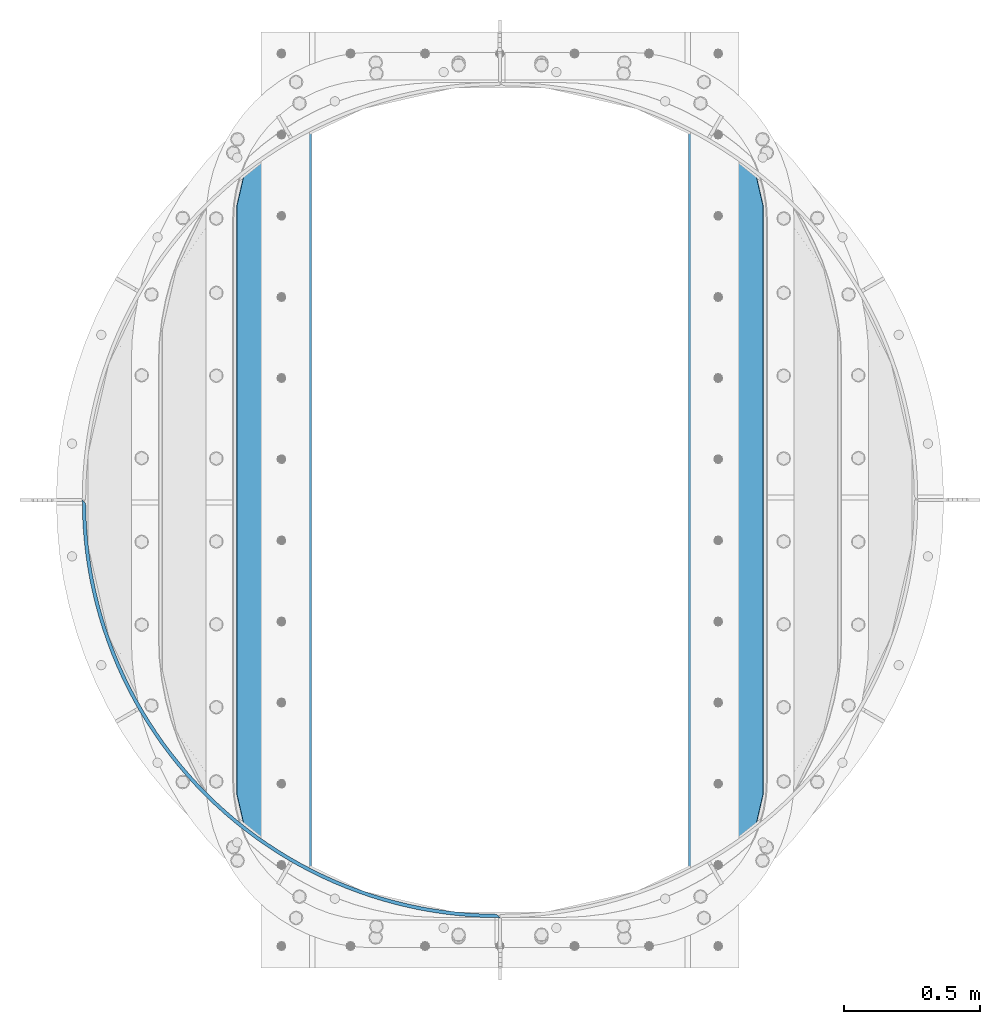
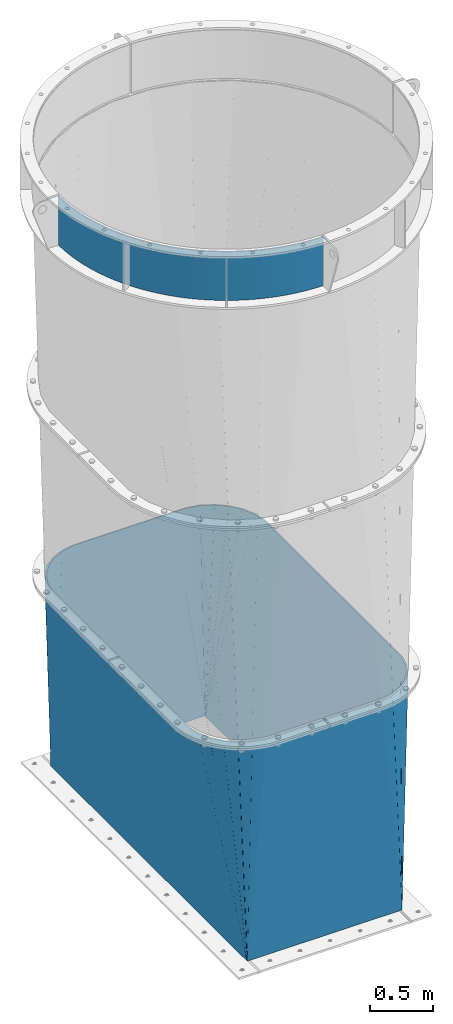
# One storey, part 6 of 15: 2 beams, 2 elements without a shape of their own.
"""IFC2X3 building model written with IfcOpenShell, lengths in millimetres."""

from ifc_helpers import new_model, si_unit, frame, origin_with_axes, place, context, subcontext, project, spatial, faceted_brep, material, type_object, element, aggregate, save


model = new_model("IFC2X3")

# Units and contexts
model_context = context("Model", 3, precision=1e-05, world=origin_with_axes())
body_context = subcontext(model_context, "Body", "Model", "MODEL_VIEW")
ifc_project = project(units=[si_unit("LENGTHUNIT", "METRE", prefix="MILLI"), si_unit("AREAUNIT", "SQUARE_METRE"), si_unit("VOLUMEUNIT", "CUBIC_METRE"), si_unit("MASSUNIT", "GRAM", prefix="KILO"), si_unit("TIMEUNIT", "SECOND"), si_unit("PLANEANGLEUNIT", "RADIAN"), si_unit("SOLIDANGLEUNIT", "STERADIAN"), si_unit("THERMODYNAMICTEMPERATUREUNIT", "DEGREE_CELSIUS"), si_unit("LUMINOUSINTENSITYUNIT", "LUMEN")], contexts=[model_context])

# Site, building, storey
site_placement = place(None, origin_with_axes())
site = spatial("IfcSite", under=ifc_project, at=site_placement, CompositionType="ELEMENT")
building_placement = place(site_placement, origin_with_axes())
building = spatial("IfcBuilding", under=site, at=building_placement, Name="Undefined", CompositionType="ELEMENT")
storey_placement = place(building_placement, origin_with_axes())
storey = spatial("IfcBuildingStorey", under=building, at=storey_placement, Name="Undefined", CompositionType="ELEMENT", Elevation=0.0)

# Assembly, beam
assembly_1_placement = place(storey_placement, origin_with_axes())
assembly_1 = element("IfcElementAssembly", 1, at=assembly_1_placement, inside=storey, Name="TRANSITION", AssemblyPlace="NOTDEFINED", PredefinedType="RIGID_FRAME")
ifc_material = material(Name="STEEL/A36")
beam_type_1 = type_object("IfcBeamType", PredefinedType="NOTDEFINED")
beam_1_placement = place(assembly_1_placement, frame((879.47499999978, 190.499999999732, 6518.28), z_axis=(0.0, 0.0, 1.0), x_axis=(-0.707106781186548, 0.707106781186548, 0.0)))
beam_1 = element("IfcBeam", 2, at=beam_1_placement, type_object=beam_type_1, material=ifc_material, Name="PLATE", context=body_context, shape_type="Brep", body=[
    faceted_brep([(2168.73185323846, 4.4901280603583, 234.95), (2150.63139313598, 4.34796445618963, 234.95), (2150.63139313598, 4.34796445618963, -234.95), (2168.73185323846, 4.4901280603583, -234.95), (13.6103320421265, 4.34796445619054, 234.95), (-4.49012806053565, 4.49012806053361, 234.95), (-4.49012806053565, 4.49012806053361, -234.95), (13.6103320421265, 4.34796445619054, -234.95), (30.1773249082131, 38.0852271696592, 234.95), (30.1773249082131, 38.0852271696592, -234.95), (38.8710731535093, 28.8273256014088, -234.95), (38.8710731535093, 28.8273256014088, 234.95), (65.8829191459708, 70.5748181123124, 234.95), (65.8829191459708, 70.5748181123124, -234.95), (74.2815798355832, 61.0484075280069, -234.95), (74.2815798355832, 61.0484075280069, 234.95), (102.591417542014, 101.92683758475, 234.95), (102.591417542014, 101.92683758475, -234.95), (110.686702211824, 92.1413194014985, -234.95), (110.686702211824, 92.1413194014985, 234.95), (140.266593240295, 132.110344928926, 234.95), (140.266593240295, 132.110344928926, -234.95), (148.05051282169, 122.075376271756, -234.95), (148.05051282169, 122.075376271756, 234.95), (178.871265390981, 161.095552667193, 234.95), (178.871265390981, 161.095552667193, -234.95), (186.336138095097, 150.821036838632, -234.95), (186.336138095097, 150.821036838632, 234.95), (218.367335843456, 188.853855898938, 234.95), (218.367335843456, 188.853855898938, -234.95), (225.50579474218, 178.349932605652, -234.95), (225.50579474218, 178.349932605652, 234.95), (258.715826744602, 215.357860530173, 234.95), (258.715826744602, 215.357860530173, -234.95), (265.520827040837, 204.634895876298, -234.95), (265.520827040837, 204.634895876298, 234.95), (299.876919005232, 240.581410308193, 234.95), (299.876919005232, 240.581410308193, -234.95), (306.341744985264, 229.649986565244, -234.95), (306.341744985264, 229.649986565244, 234.95), (341.809991596724, 264.499612634644, 234.95), (341.809991596724, 264.499612634644, -234.95), (347.928263257818, 253.370517798088, -234.95), (347.928263257818, 253.370517798088, 234.95), (384.473661639071, 287.088863131509, 234.95), (384.473661639071, 287.088863131509, -234.95), (390.239340985765, 275.773080274318, -234.95), (390.239340985765, 275.773080274318, 234.95), (427.825825240789, 308.326868935782, 234.95), (427.825825240789, 308.326868935782, -234.95), (433.233222243668, 296.835565369465, -234.95), (433.233222243668, 296.835565369465, 234.95), (471.823699050373, 328.192670699828, 234.95), (471.823699050373, 328.192670699828, -234.95), (476.867477261437, 316.537186953643, -234.95), (476.867477261437, 316.537186953643, 234.95), (516.423862478301, 346.666663275734, 234.95), (516.423862478301, 346.666663275734, -234.95), (521.099044297397, 334.858501904954, -234.95), (521.099044297397, 334.858501904954, 234.95), (561.582300547911, 363.73061506322, 234.95), (561.582300547911, 363.73061506322, -234.95), (565.884272135028, 351.781429297502, -234.95), (565.884272135028, 351.781429297502, 234.95), (607.254447332874, 379.367686002027, 234.95), (607.254447332874, 379.367686002027, -234.95), (611.178963161437, 367.289268245079, -234.95), (611.178963161437, 367.289268245079, 234.95), (653.395229938378, 393.562444191024, 234.95), (653.395229938378, 393.562444191024, -234.95), (656.938416985078, 381.366714382928, -234.95), (656.938416985078, 381.366714382928, 234.95), (699.959112982635, 406.300881117635, 234.95), (699.959112982635, 406.300881117635, -234.95), (703.11747454963, 393.999874971302, -234.95), (703.11747454963, 393.999874971302, 234.95), (746.900143534807, 417.570425482542, 234.95), (746.900143534807, 417.570425482542, -234.95), (749.670562700545, 405.17628260592, -234.95), (749.670562700545, 405.17628260592, 234.95), (794.171996464998, 427.359955606045, 234.95), (794.171996464998, 427.359955606045, -234.95), (796.551739160238, 414.884907521791, -234.95), (796.551739160238, 414.884907521791, 234.95), (841.728020161566, 435.659810403817, 234.95), (841.728020161566, 435.659810403817, -234.95), (843.714737867578, 423.116168478259, -234.95), (843.714737867578, 423.116168478259, 234.95), (889.52128257063, 442.461798921226, 234.95), (889.52128257063, 442.461798921226, -234.95), (891.113014636898, 429.861942214533, -234.95), (891.113014636898, 429.861942214533, 234.95), (937.504617512343, 447.759208416819, 234.95), (937.504617512343, 447.759208416819, -234.95), (938.699793091489, 435.115571466361, -234.95), (938.699793091489, 435.115571466361, 234.95), (985.630671228216, 451.546810986989, 234.95), (985.630671228216, 451.546810986989, -234.95), (986.42811082624, 438.871871535951, -234.95), (986.42811082624, 438.871871535951, 234.95), (1033.85194911356, 453.820868725281, 234.95), (1033.85194911356, 453.820868725281, -234.95), (1034.25086575385, 441.127135408636, -234.95), (1034.25086575385, 441.127135408636, 234.95), (1082.12086258893, 454.579137411258, 234.95), (1082.12086258893, 454.579137411258, -234.95), (1082.12086258893, 441.879137411258, -234.95), (1082.12086258893, 441.879137411258, 234.95), (1130.3897760643, 453.820868725272, 234.95), (1130.3897760643, 453.820868725272, -234.95), (1129.99085942401, 441.127135408629, -234.95), (1129.99085942401, 441.127135408629, 234.95), (1178.61105394964, 451.546810986973, 234.95), (1178.61105394964, 451.546810986973, -234.95), (1177.81361435162, 438.871871535935, -234.95), (1177.81361435162, 438.871871535935, 234.95), (1226.73710766552, 447.759208416796, 234.95), (1226.73710766552, 447.759208416796, -234.95), (1225.54193208637, 435.115571466338, -234.95), (1225.54193208637, 435.115571466338, 234.95), (1274.72044260723, 442.461798921194, 234.95), (1274.72044260723, 442.461798921194, -234.95), (1273.12871054096, 429.861942214502, -234.95), (1273.12871054096, 429.861942214502, 234.95), (1322.51370501629, 435.659810403778, 234.95), (1322.51370501629, 435.659810403778, -234.95), (1320.52698731028, 423.116168478221, -234.95), (1320.52698731028, 423.116168478221, 234.95), (1370.06972871286, 427.359955605998, 234.95), (1370.06972871286, 427.359955605998, -234.95), (1367.68998601762, 414.884907521745, -234.95), (1367.68998601762, 414.884907521745, 234.95), (1417.34158164306, 417.570425482488, 234.95), (1417.34158164306, 417.570425482488, -234.95), (1414.57116247732, 405.176282605867, -234.95), (1414.57116247732, 405.176282605867, 234.95), (1464.28261219523, 406.300881117574, 234.95), (1464.28261219523, 406.300881117574, -234.95), (1461.12425062824, 393.999874971241, -234.95), (1461.12425062824, 393.999874971241, 234.95), (1510.84649523949, 393.562444190955, 234.95), (1510.84649523949, 393.562444190955, -234.95), (1507.30330819279, 381.36671438286, -234.95), (1507.30330819279, 381.36671438286, 234.95), (1556.98727784499, 379.36768600195, 234.95), (1556.98727784499, 379.36768600195, -234.95), (1553.06276201643, 367.289268245003, -234.95), (1553.06276201643, 367.289268245003, 234.95), (1602.65942462996, 363.730615063135, 234.95), (1602.65942462996, 363.730615063135, -234.95), (1598.35745304285, 351.781429297419, -234.95), (1598.35745304285, 351.781429297419, 234.95), (1647.81786269957, 346.666663275642, 234.95), (1647.81786269957, 346.666663275642, -234.95), (1643.14268088048, 334.858501904863, -234.95), (1643.14268088048, 334.858501904863, 234.95), (1692.4180261275, 328.192670699729, 234.95), (1692.4180261275, 328.192670699729, -234.95), (1687.37424791644, 316.537186953544, -234.95), (1687.37424791644, 316.537186953544, 234.95), (1736.41589993709, 308.326868935676, 234.95), (1736.41589993709, 308.326868935676, -234.95), (1731.00850293421, 296.835565369359, -234.95), (1731.00850293421, 296.835565369359, 234.95), (1779.76806353881, 287.088863131397, 234.95), (1779.76806353881, 287.088863131397, -234.95), (1774.00238419212, 275.773080274206, -234.95), (1774.00238419212, 275.773080274206, 234.95), (1822.43173358116, 264.499612634525, 234.95), (1822.43173358116, 264.499612634525, -234.95), (1816.31346192007, 253.370517797969, -234.95), (1816.31346192007, 253.370517797969, 234.95), (1864.36480617266, 240.581410308067, 234.95), (1864.36480617266, 240.581410308067, -234.95), (1857.89998019263, 229.649986565118, -234.95), (1857.89998019263, 229.649986565118, 234.95), (1905.52589843329, 215.357860530039, 234.95), (1905.52589843329, 215.357860530039, -234.95), (1898.72089813706, 204.634895876166, -234.95), (1898.72089813706, 204.634895876166, 234.95), (1945.87438933444, 188.853855898798, 234.95), (1945.87438933444, 188.853855898798, -234.95), (1938.73593043572, 178.349932605514, -234.95), (1938.73593043572, 178.349932605514, 234.95), (1985.37045978692, 161.095552667047, 234.95), (1985.37045978692, 161.095552667047, -234.95), (1977.90558708281, 150.821036838488, -234.95), (1977.90558708281, 150.821036838488, 234.95), (2023.97513193761, 132.110344928774, 234.95), (2023.97513193761, 132.110344928774, -234.95), (2016.19121235622, 122.075376271606, -234.95), (2016.19121235622, 122.075376271606, 234.95), (2061.6503076359, 101.926837584591, 234.95), (2061.6503076359, 101.926837584591, -234.95), (2053.55502296609, 92.1413194013419, -234.95), (2053.55502296609, 92.1413194013419, 234.95), (2098.35880603195, 70.5748181121483, 234.95), (2098.35880603195, 70.5748181121483, -234.95), (2089.96014534234, 61.0484075278443, -234.95), (2089.96014534234, 61.0484075278443, 234.95), (2134.06440026971, 38.0852271694891, 234.95), (2134.06440026971, 38.0852271694891, -234.95), (2125.37065202442, 28.8273256012403, -234.95), (2125.37065202442, 28.8273256012403, 234.95)], [[[0, 1, 2, 3]], [[4, 5, 6, 7]], [[6, 5, 8, 9]], [[10, 11, 4, 7]], [[9, 8, 12, 13]], [[11, 10, 14, 15]], [[13, 12, 16, 17]], [[15, 14, 18, 19]], [[17, 16, 20, 21]], [[19, 18, 22, 23]], [[21, 20, 24, 25]], [[23, 22, 26, 27]], [[25, 24, 28, 29]], [[27, 26, 30, 31]], [[29, 28, 32, 33]], [[31, 30, 34, 35]], [[33, 32, 36, 37]], [[35, 34, 38, 39]], [[37, 36, 40, 41]], [[39, 38, 42, 43]], [[41, 40, 44, 45]], [[43, 42, 46, 47]], [[45, 44, 48, 49]], [[47, 46, 50, 51]], [[49, 48, 52, 53]], [[51, 50, 54, 55]], [[53, 52, 56, 57]], [[55, 54, 58, 59]], [[57, 56, 60, 61]], [[59, 58, 62, 63]], [[61, 60, 64, 65]], [[63, 62, 66, 67]], [[65, 64, 68, 69]], [[67, 66, 70, 71]], [[69, 68, 72, 73]], [[71, 70, 74, 75]], [[73, 72, 76, 77]], [[75, 74, 78, 79]], [[77, 76, 80, 81]], [[79, 78, 82, 83]], [[81, 80, 84, 85]], [[83, 82, 86, 87]], [[85, 84, 88, 89]], [[87, 86, 90, 91]], [[89, 88, 92, 93]], [[91, 90, 94, 95]], [[93, 92, 96, 97]], [[95, 94, 98, 99]], [[97, 96, 100, 101]], [[99, 98, 102, 103]], [[101, 100, 104, 105]], [[103, 102, 106, 107]], [[105, 104, 108, 109]], [[107, 106, 110, 111]], [[109, 108, 112, 113]], [[111, 110, 114, 115]], [[113, 112, 116, 117]], [[115, 114, 118, 119]], [[117, 116, 120, 121]], [[119, 118, 122, 123]], [[121, 120, 124, 125]], [[123, 122, 126, 127]], [[125, 124, 128, 129]], [[127, 126, 130, 131]], [[129, 128, 132, 133]], [[131, 130, 134, 135]], [[133, 132, 136, 137]], [[135, 134, 138, 139]], [[137, 136, 140, 141]], [[139, 138, 142, 143]], [[141, 140, 144, 145]], [[143, 142, 146, 147]], [[145, 144, 148, 149]], [[147, 146, 150, 151]], [[149, 148, 152, 153]], [[151, 150, 154, 155]], [[153, 152, 156, 157]], [[155, 154, 158, 159]], [[157, 156, 160, 161]], [[159, 158, 162, 163]], [[161, 160, 164, 165]], [[163, 162, 166, 167]], [[165, 164, 168, 169]], [[167, 166, 170, 171]], [[169, 168, 172, 173]], [[171, 170, 174, 175]], [[173, 172, 176, 177]], [[175, 174, 178, 179]], [[177, 176, 180, 181]], [[179, 178, 182, 183]], [[181, 180, 184, 185]], [[183, 182, 186, 187]], [[185, 184, 188, 189]], [[187, 186, 190, 191]], [[189, 188, 192, 193]], [[191, 190, 194, 195]], [[193, 192, 196, 197]], [[195, 194, 198, 199]], [[197, 196, 200, 201]], [[199, 198, 202, 203]], [[201, 200, 0, 3]], [[200, 196, 192, 188, 184, 180, 176, 172, 168, 164, 160, 156, 152, 148, 144, 140, 136, 132, 128, 124, 120, 116, 112, 108, 104, 100, 96, 92, 88, 84, 80, 76, 72, 68, 64, 60, 56, 52, 48, 44, 40, 36, 32, 28, 24, 20, 16, 12, 8, 5, 4, 11, 15, 19, 23, 27, 31, 35, 39, 43, 47, 51, 55, 59, 63, 67, 71, 75, 79, 83, 87, 91, 95, 99, 103, 107, 111, 115, 119, 123, 127, 131, 135, 139, 143, 147, 151, 155, 159, 163, 167, 171, 175, 179, 183, 187, 191, 195, 199, 203, 1, 0]], [[203, 202, 2, 1]], [[202, 198, 194, 190, 186, 182, 178, 174, 170, 166, 162, 158, 154, 150, 146, 142, 138, 134, 130, 126, 122, 118, 114, 110, 106, 102, 98, 94, 90, 86, 82, 78, 74, 70, 66, 62, 58, 54, 50, 46, 42, 38, 34, 30, 26, 22, 18, 14, 10, 7, 6, 9, 13, 17, 21, 25, 29, 33, 37, 41, 45, 49, 53, 57, 61, 65, 69, 73, 77, 81, 85, 89, 93, 97, 101, 105, 109, 113, 117, 121, 125, 129, 133, 137, 141, 145, 149, 153, 157, 161, 165, 169, 173, 177, 181, 185, 189, 193, 197, 201, 3, 2]]]),
])
aggregate(assembly_1, [beam_1])

assembly_2_placement = place(storey_placement, origin_with_axes())
assembly_2 = element("IfcElementAssembly", 3, at=assembly_2_placement, inside=storey, Name="TRANSITION", AssemblyPlace="NOTDEFINED", PredefinedType="RIGID_FRAME")
beam_type_2 = type_object("IfcBeamType", PredefinedType="NOTDEFINED")
beam_2_placement = place(assembly_2_placement, frame((879.475000000001, 1720.85, 6242.045), z_axis=(1.0, 0.0, 0.0), x_axis=(0.0, 0.0, -1.0)))
beam_2 = element("IfcBeam", 4, at=beam_2_placement, type_object=beam_type_2, material=ifc_material, Name="TRANSITION", context=body_context, shape_type="Brep", body=[
    faceted_brep([(6223.0, 1554.1625, -705.4375), (6223.0, 1554.1625, -706.4375), (4150.78000009537, 1470.05574212632, -743.428741508502), (4150.78000009537, 1470.05574212632, -742.761735241413), (4150.78000009537, 1519.69175465465, -639.396018429843), (6223.0, 1554.1625, -703.4375), (4150.78000009537, 1519.69175465465, -638.062005895665), (4150.78000009537, 1545.27732812286, -526.508905574268), (6223.0, 1554.1625, 703.4375), (4150.78000009537, 1545.27732812286, 526.508905574268), (4150.78000009537, 1519.69175465465, 638.062005895665), (6223.0, 1554.1625, 704.4375), (4150.78000009537, 1519.69175465465, 638.729012162754), (4150.78000009537, 1470.05574212632, 742.094728974324), (6223.0, 1554.1625, 706.4375), (4150.78000009537, 1470.05574212632, 743.428741508502), (4150.78000009537, 1398.41613641533, 832.978248647238), (6223.0, 1553.1625, 706.4375), (4150.78000009537, 1397.74913014824, 832.978248647238), (4150.78000009537, 1308.19962300951, 904.617854358227), (6223.0, 1552.1625, 706.4375), (4150.78000009537, 1307.53261674242, 904.617854358227), (4150.78000009537, 1204.16689993085, 954.253866886554), (6223.0, 1551.1625, 706.4375), (4150.78000009537, 1203.49989366376, 954.253866886554), (4150.78000009537, 1091.94679334236, 979.839440354765), (6223.0, -1551.1625, 706.4375), (4150.78000009537, -1091.94679334236, 979.839440354765), (4150.78000009537, -1203.49989366376, 954.253866886554), (6223.0, -1552.1625, 706.4375), (4150.78000009537, -1204.16689993085, 954.253866886554), (4150.78000009537, -1307.53261674242, 904.617854358227), (6223.0, -1553.1625, 706.4375), (4150.78000009537, -1308.19962300951, 904.617854358227), (4150.78000009537, -1397.74913014824, 832.978248647238), (6223.0, -1554.1625, 706.4375), (4150.78000009537, -1398.41613641533, 832.978248647238), (4150.78000009537, -1470.05574212632, 743.428741508502), (6223.0, -1554.1625, 705.4375), (4150.78000009537, -1470.05574212632, 742.761735241413), (4150.78000009537, -1519.69175465465, 639.396018429843), (6223.0, -1554.1625, 703.4375), (4150.78000009537, -1519.69175465465, 638.062005895665), (4150.78000009537, -1545.27732812286, 526.508905574268), (6223.0, -1554.1625, -703.4375), (4150.78000009537, -1545.27732812286, -526.508905574268), (4150.78000009537, -1519.69175465465, -638.062005895665), (6223.0, -1554.1625, -704.4375), (4150.78000009537, -1519.69175465465, -638.729012162754), (4150.78000009537, -1470.05574212632, -742.094728974324), (6223.0, -1554.1625, -706.4375), (4150.78000009537, -1470.05574212632, -743.428741508502), (4150.78000009537, -1398.41613641533, -832.978248647238), (6223.0, -1553.1625, -706.4375), (4150.78000009537, -1397.74913014824, -832.978248647238), (4150.78000009537, -1308.19962300951, -904.617854358226), (6223.0, -1552.1625, -706.4375), (4150.78000009537, -1307.53261674242, -904.617854358226), (4150.78000009537, -1204.16689993085, -954.253866886554), (6223.0, -1551.1625, -706.4375), (4150.78000009537, -1203.49989366376, -954.253866886554), (4150.78000009537, -1091.94679334236, -979.839440354765), (6223.0, 1551.1625, -706.4375), (4150.78000009537, 1091.94679334236, -979.839440354765), (4150.78000009537, 1203.49989366376, -954.253866886554), (6223.0, 1552.1625, -706.4375), (4150.78000009537, 1204.16689993085, -954.253866886554), (4150.78000009537, 1307.53261674242, -904.617854358226), (6223.0, 1553.1625, -706.4375), (4150.78000009537, 1308.19962300951, -904.617854358226), (4150.78000009537, 1397.74913014824, -832.978248647238), (4150.78000009537, 1398.41613641533, -832.978248647238), (6223.0, 1540.4625, -693.7375), (6223.0, 1539.4625, -693.7375), (6223.0, 1538.4625, -693.7375), (6223.0, -1538.4625, -693.7375), (6223.0, -1539.4625, -693.7375), (6223.0, -1540.4625, -693.7375), (6223.0, -1541.4625, -693.7375), (6223.0, -1541.4625, -692.7375), (6223.0, -1541.4625, -690.7375), (6223.0, -1541.4625, 690.7375), (6223.0, -1541.4625, 691.7375), (6223.0, -1541.4625, 693.7375), (6223.0, -1540.4625, 693.7375), (6223.0, -1539.4625, 693.7375), (6223.0, -1538.4625, 693.7375), (6223.0, 1538.4625, 693.7375), (6223.0, 1539.4625, 693.7375), (6223.0, 1540.4625, 693.7375), (6223.0, 1541.4625, 693.7375), (6223.0, 1541.4625, 692.7375), (6223.0, 1541.4625, 690.7375), (6223.0, 1541.4625, -690.7375), (6223.0, 1541.4625, -691.7375), (6223.0, 1541.4625, -693.7375), (4150.78000009537, -1083.00216346464, 967.164814477212), (4150.78000009537, 1083.00216346464, 967.164814477212), (4150.78000009537, 1193.6333373371, 941.7906920294), (4150.78000009537, 1194.30034360419, 941.7906920294), (4150.78000009537, 1296.81179829335, 892.564894480645), (4150.78000009537, 1297.47880456043, 892.564894480645), (4150.78000009537, 1386.28823312778, 821.517351626772), (4150.78000009537, 1386.95523939487, 821.517351626772), (4150.78000009537, 1458.00278224874, 732.707923059431), (4150.78000009537, 1458.00278224874, 732.040916792342), (4150.78000009537, 1507.22857979749, 629.529462103182), (4150.78000009537, 1507.22857979749, 628.195449569004), (4150.78000009537, 1532.60270224531, 517.564275696544), (4150.78000009537, 1532.60270224531, -517.564275696544), (4150.78000009537, 1507.22857979749, -628.195449569004), (4150.78000009537, 1507.22857979749, -628.862455836093), (4150.78000009537, 1458.00278224874, -731.373910525253), (4150.78000009537, 1458.00278224874, -732.707923059431), (4150.78000009537, 1386.95523939487, -821.517351626772), (4150.78000009537, 1386.28823312778, -821.517351626772), (4150.78000009537, 1297.47880456043, -892.564894480646), (4150.78000009537, 1296.81179829335, -892.564894480646), (4150.78000009537, 1194.30034360419, -941.7906920294), (4150.78000009537, 1193.6333373371, -941.7906920294), (4150.78000009537, 1083.00216346464, -967.164814477212), (4150.78000009537, -1083.00216346464, -967.164814477212), (4150.78000009537, -1193.6333373371, -941.7906920294), (4150.78000009537, -1194.30034360419, -941.7906920294), (4150.78000009537, -1296.81179829335, -892.564894480646), (4150.78000009537, -1297.47880456044, -892.564894480646), (4150.78000009537, -1386.28823312778, -821.517351626772), (4150.78000009537, -1386.95523939487, -821.517351626772), (4150.78000009537, -1458.00278224874, -732.707923059431), (4150.78000009537, -1458.00278224874, -732.040916792342), (4150.78000009537, -1507.22857979749, -629.529462103182), (4150.78000009537, -1507.22857979749, -628.195449569004), (4150.78000009537, -1532.60270224531, -517.564275696544), (4150.78000009537, -1532.60270224531, 517.564275696544), (4150.78000009537, -1507.22857979749, 628.195449569004), (4150.78000009537, -1507.22857979749, 628.862455836093), (4150.78000009537, -1458.00278224874, 731.373910525253), (4150.78000009537, -1458.00278224874, 732.707923059431), (4150.78000009537, -1386.95523939487, 821.517351626772), (4150.78000009537, -1386.28823312778, 821.517351626772), (4150.78000009537, -1297.47880456044, 892.564894480645), (4150.78000009537, -1296.81179829335, 892.564894480645), (4150.78000009537, -1194.30034360419, 941.7906920294), (4150.78000009537, -1193.6333373371, 941.7906920294)], [[[0, 1, 2, 3]], [[0, 3, 4]], [[5, 0, 4, 6]], [[5, 6, 7]], [[8, 5, 7, 9]], [[8, 9, 10]], [[11, 8, 10, 12]], [[11, 12, 13]], [[14, 11, 13, 15]], [[14, 15, 16]], [[17, 14, 16, 18]], [[17, 18, 19]], [[20, 17, 19, 21]], [[20, 21, 22]], [[23, 20, 22, 24]], [[23, 24, 25]], [[26, 23, 25, 27]], [[26, 27, 28]], [[29, 26, 28, 30]], [[29, 30, 31]], [[32, 29, 31, 33]], [[32, 33, 34]], [[35, 32, 34, 36]], [[35, 36, 37]], [[38, 35, 37, 39]], [[38, 39, 40]], [[41, 38, 40, 42]], [[41, 42, 43]], [[44, 41, 43, 45]], [[44, 45, 46]], [[47, 44, 46, 48]], [[47, 48, 49]], [[50, 47, 49, 51]], [[50, 51, 52]], [[53, 50, 52, 54]], [[53, 54, 55]], [[56, 53, 55, 57]], [[56, 57, 58]], [[59, 56, 58, 60]], [[59, 60, 61]], [[62, 59, 61, 63]], [[62, 63, 64]], [[65, 62, 64, 66]], [[65, 66, 67]], [[68, 65, 67, 69]], [[68, 69, 70]], [[1, 68, 70, 71]], [[72, 73, 74, 75, 76, 77, 78, 79, 80, 81, 82, 83, 84, 85, 86, 87, 88, 89, 90, 91, 92, 93, 94, 95], [0, 5, 8, 11, 14, 17, 20, 23, 26, 29, 32, 35, 38, 41, 44, 47, 50, 53, 56, 59, 62, 65, 68, 1]], [[87, 86, 96, 97]], [[87, 97, 98]], [[88, 87, 98, 99]], [[88, 99, 100]], [[89, 88, 100, 101]], [[89, 101, 102]], [[90, 89, 102, 103]], [[90, 103, 104]], [[91, 90, 104, 105]], [[91, 105, 106]], [[92, 91, 106, 107]], [[92, 107, 108]], [[93, 92, 108, 109]], [[93, 109, 110]], [[94, 93, 110, 111]], [[94, 111, 112]], [[95, 94, 112, 113]], [[95, 113, 114]], [[72, 95, 114, 115]], [[72, 115, 116]], [[73, 72, 116, 117]], [[73, 117, 118]], [[74, 73, 118, 119]], [[74, 119, 120]], [[75, 74, 120, 121]], [[75, 121, 122]], [[76, 75, 122, 123]], [[76, 123, 124]], [[77, 76, 124, 125]], [[77, 125, 126]], [[78, 77, 126, 127]], [[78, 127, 128]], [[79, 78, 128, 129]], [[79, 129, 130]], [[80, 79, 130, 131]], [[80, 131, 132]], [[81, 80, 132, 133]], [[81, 133, 134]], [[82, 81, 134, 135]], [[82, 135, 136]], [[83, 82, 136, 137]], [[83, 137, 138]], [[84, 83, 138, 139]], [[84, 139, 140]], [[85, 84, 140, 141]], [[85, 141, 142]], [[86, 85, 142, 143]], [[86, 143, 96]], [[24, 22, 21, 19, 18, 16, 15, 13, 12, 10, 9, 7, 6, 4, 3, 2, 71, 70, 69, 67, 66, 64, 63, 61, 60, 58, 57, 55, 54, 52, 51, 49, 48, 46, 45, 43, 42, 40, 39, 37, 36, 34, 33, 31, 30, 28, 27, 25], [142, 141, 140, 139, 138, 137, 136, 135, 134, 133, 132, 131, 130, 129, 128, 127, 126, 125, 124, 123, 122, 121, 120, 119, 118, 117, 116, 115, 114, 113, 112, 111, 110, 109, 108, 107, 106, 105, 104, 103, 102, 101, 100, 99, 98, 97, 96, 143]], [[1, 71, 2]]]),
])
aggregate(assembly_2, [beam_2])

save(model, "model.ifc")
